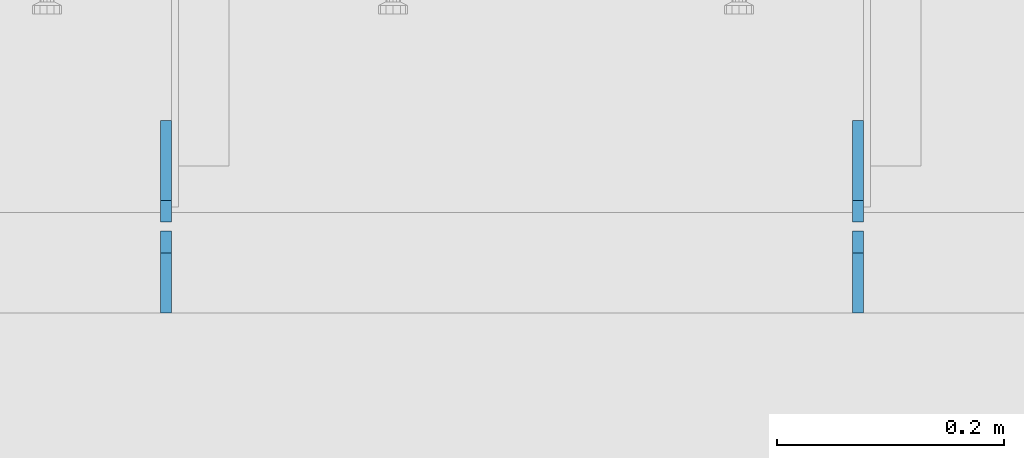
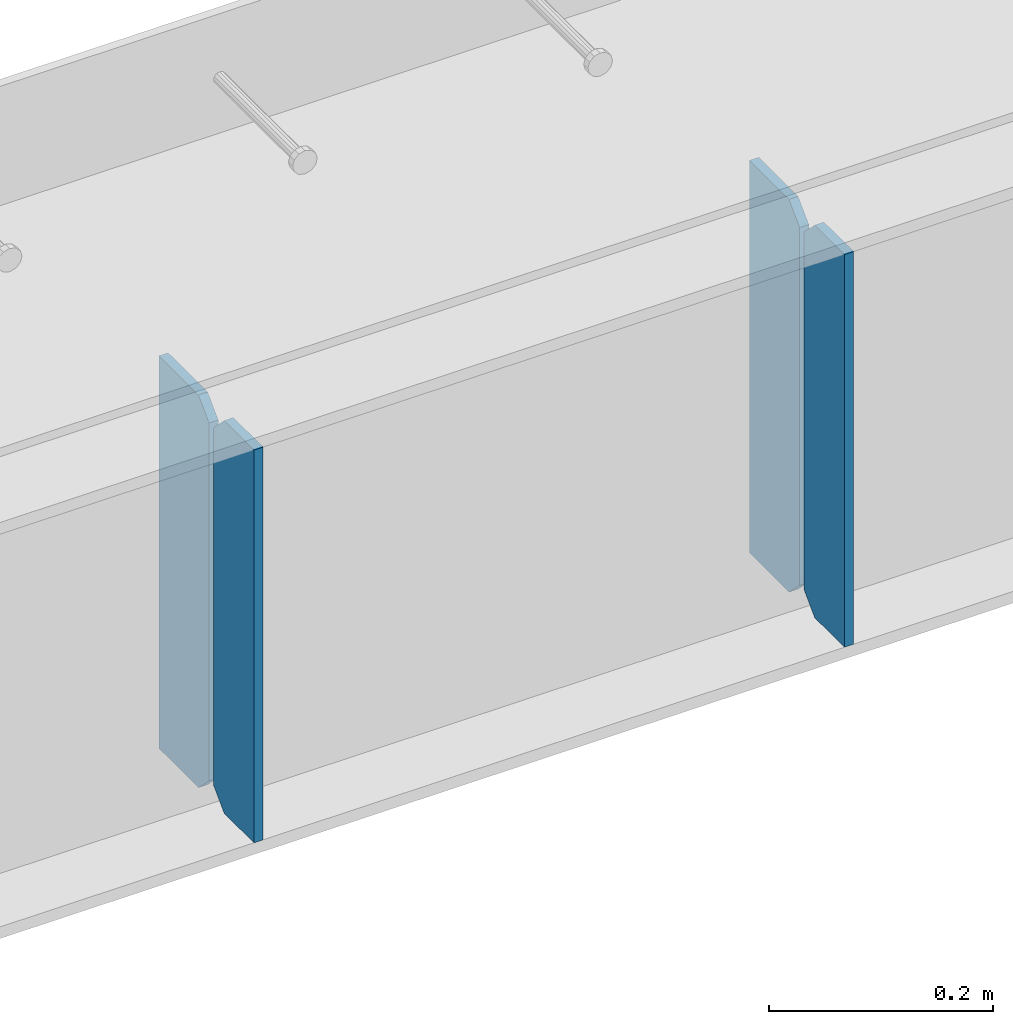
# One storey, part 1613 of 1763: 4 plates, 1 element without a shape of its own.
"""IFC2X3 building model written with IfcOpenShell, lengths in millimetres."""

import ifcopenshell
import ifcopenshell.guid

model = None  # the IFC model being written
_history = None  # IfcOwnerHistory: only IFC2X3 demands one
_inside = {}  # id of a spatial element -> (the spatial element, [elements in it])
_under = {}  # id of a project, library or spatial element -> (it, [spatial elements below it])
_declared = {}  # id of a project -> (the project, [libraries it declares])
_typed = {}  # id of a type object -> (the type object, [elements of that type])
_made_of = {}  # id of a material, layer set ... -> (it, [elements and type objects made of it])


def new_model(schema):
    """Start an empty IFC model of exactly this schema.

    Asked for "IFC4X3", IfcOpenShell would pick the latest addendum, in which some entities
    have other attributes; the version numbers below select the first issue.
    IFC2X3 requires an IfcOwnerHistory on every rooted entity: one is made here for all.
    """
    global model, _history
    if schema == "IFC4X3":
        model = ifcopenshell.file(schema_version=(4, 3, 0, 0))
    else:
        model = ifcopenshell.file(schema=schema)
    _inside.clear()
    _under.clear()
    _declared.clear()
    _typed.clear()
    _made_of.clear()
    _history = None
    if model.schema == "IFC2X3":
        org = make("IfcOrganization", Name="unknown")
        user = make(
            "IfcPersonAndOrganization",
            ThePerson=make("IfcPerson", FamilyName="unknown"),
            TheOrganization=org,
        )
        app = make(
            "IfcApplication",
            ApplicationDeveloper=org,
            Version="unknown",
            ApplicationFullName="unknown",
            ApplicationIdentifier="unknown",
        )
        _history = make(
            "IfcOwnerHistory",
            OwningUser=user,
            OwningApplication=app,
            ChangeAction="ADDED",
            CreationDate=0,
        )
    return model


def make(cls, **values):
    """One entity of the class cls with the attributes given. An attribute that is None is left unset."""
    return model.create_entity(
        cls, **{name: value for name, value in values.items() if value is not None}
    )


def rooted(cls, **values):
    """An entity with a GlobalId (a new one), such as an element, a storey or a relation."""
    return make(cls, GlobalId=ifcopenshell.guid.new(), OwnerHistory=_history, **values)


def si_unit(unit_type, name, prefix=None):
    """IfcSIUnit, for example si_unit("LENGTHUNIT", "METRE", prefix="MILLI")."""
    return make("IfcSIUnit", UnitType=unit_type, Prefix=prefix, Name=name)


def assignment(units):
    """IfcUnitAssignment: the units of a project."""
    return None if units is None else make("IfcUnitAssignment", Units=units)


def point(xyz):
    """IfcCartesianPoint."""
    return None if xyz is None else make("IfcCartesianPoint", Coordinates=xyz)


def direction(xyz):
    """IfcDirection."""
    return None if xyz is None else make("IfcDirection", DirectionRatios=xyz)


def frame(location, z_axis=None, x_axis=None):
    """IfcAxis2Placement3D, a coordinate frame: its origin and axes. An axis left out is left unset."""
    return make(
        "IfcAxis2Placement3D",
        Location=point(location),
        Axis=direction(z_axis),
        RefDirection=direction(x_axis),
    )


def origin_with_axes():
    """The frame at (0, 0, 0) with the z axis (0, 0, 1) and the x axis (1, 0, 0) written out."""
    return frame((0.0, 0.0, 0.0), z_axis=(0.0, 0.0, 1.0), x_axis=(1.0, 0.0, 0.0))


def place(relative_to, where):
    """IfcLocalPlacement: puts the frame where relative to a parent placement (None: the world)."""
    return make(
        "IfcLocalPlacement", PlacementRelTo=relative_to, RelativePlacement=where
    )


def context(
    kind, dimensions, precision=None, world=None, true_north=None, identifier=None
):
    """IfcGeometricRepresentationContext, for example the 3D "Model" context."""
    return make(
        "IfcGeometricRepresentationContext",
        ContextIdentifier=identifier,
        ContextType=kind,
        CoordinateSpaceDimension=dimensions,
        Precision=precision,
        WorldCoordinateSystem=world,
        TrueNorth=true_north,
    )


def subcontext(parent, identifier, kind, view, scale=None):
    """IfcGeometricRepresentationSubContext, for example "Body" below "Model"."""
    return make(
        "IfcGeometricRepresentationSubContext",
        ContextIdentifier=identifier,
        ContextType=kind,
        ParentContext=parent,
        TargetScale=scale,
        TargetView=view,
    )


def project(units=None, contexts=None):
    """IfcProject with its units and contexts."""
    return rooted(
        "IfcProject",
        Name="project",
        RepresentationContexts=contexts,
        UnitsInContext=assignment(units),
    )


def spatial(cls, under=None, at=None, **own):
    """A site, building, storey or space (cls), placed at a placement, below another one or the project."""
    s = rooted(cls, ObjectPlacement=at, **own)
    if under is not None:
        _under.setdefault(under.id(), (under, []))[1].append(s)
    return s


def faces_of(points, faces, orient=None, outer=None):
    """IfcFace entities. A face is a list of loops; a loop is a list of indices into points, from 0.

    orient and outer hold one flag for each loop. By default every Orientation is true, the
    first loop of a face is its IfcFaceOuterBound and the others are IfcFaceBound.
    """
    made = []
    for i, loops in enumerate(faces):
        bounds = []
        for j, loop in enumerate(loops):
            is_outer = j == 0 if outer is None else outer[i][j]
            bounds.append(
                make(
                    "IfcFaceOuterBound" if is_outer else "IfcFaceBound",
                    Bound=make("IfcPolyLoop", Polygon=[points[k] for k in loop]),
                    Orientation=True if orient is None else orient[i][j],
                )
            )
        made.append(make("IfcFace", Bounds=bounds))
    return made


def faceted_brep(points, faces, orient=None, outer=None, voids=None):
    """IfcFacetedBrep: a solid bounded by flat faces; with voids (closed shells), ...WithVoids."""
    shared = [point(p) for p in points]
    hull = make("IfcClosedShell", CfsFaces=faces_of(shared, faces, orient, outer))
    if voids is None:
        return make("IfcFacetedBrep", Outer=hull)
    return make(
        "IfcFacetedBrepWithVoids",
        Outer=hull,
        Voids=[
            make(cls, CfsFaces=faces_of(shared, fs, o, b)) for cls, fs, o, b in voids
        ],
    )


def shape(context_of_items, identifier, shape_type, items):
    """IfcShapeRepresentation: the items that make up one representation, for example the "Body"."""
    return make(
        "IfcShapeRepresentation",
        ContextOfItems=context_of_items,
        RepresentationIdentifier=identifier,
        RepresentationType=shape_type,
        Items=items,
    )


def material(Name=None, Category=None):
    """IfcMaterial."""
    return make("IfcMaterial", Name=Name, Category=Category)


def made_of(thing, what):
    """Note that an element or type object is made of a material, layer set ...; save() writes the relation."""
    if what is not None:
        _made_of.setdefault(what.id(), (what, []))[1].append(thing)
    return thing


def type_object(cls, material=None, **own):
    """A type object (cls), such as IfcWallType, which elements share."""
    return made_of(rooted(cls, **own), material)


def element(
    cls,
    number,
    at=None,
    inside=None,
    cuts=None,
    type_object=None,
    material=None,
    context=None,
    identifier="Body",
    shape_type=None,
    held_by="IfcProductDefinitionShape",
    body=None,
    shapes=None,
    **own,
):
    """One element of the class cls, such as IfcWall. Its Tag is "e" and its number.

    at: its placement. inside: the storey or other place that contains it. cuts: it is an
    opening in that element (IfcRelVoidsElement). A single representation is given by context,
    identifier, shape_type and body (its items); several are given by shapes. held_by: the class
    of the entity that holds the representations. save() writes the other relations.
    """
    e = rooted(cls, Tag="e%d" % number, ObjectPlacement=at, **own)
    if body is not None:
        shapes = [shape(context, identifier, shape_type, body)]
    if shapes is not None:
        e.Representation = make(held_by, Representations=shapes)
    if inside is not None:
        _inside.setdefault(inside.id(), (inside, []))[1].append(e)
    if cuts is not None:
        rooted(
            "IfcRelVoidsElement", RelatingBuildingElement=cuts, RelatedOpeningElement=e
        )
    if type_object is not None:
        _typed.setdefault(type_object.id(), (type_object, []))[1].append(e)
    return made_of(e, material)


def aggregate(whole, parts):
    """IfcRelAggregates: a whole, such as a stair, and the parts it consists of."""
    return rooted("IfcRelAggregates", RelatingObject=whole, RelatedObjects=parts)


def save(model, path):
    """Write the relations noted so far, then the file.

    IfcRelAggregates (storeys below a building ...), IfcRelContainedInSpatialStructure (elements
    in a storey), IfcRelDefinesByType, IfcRelAssociatesMaterial and IfcRelDeclares: one each for
    every whole, place, type object, material and project.
    """
    for whole, parts in _under.values():
        aggregate(whole, parts)
    for where, things in _inside.values():
        rooted(
            "IfcRelContainedInSpatialStructure",
            RelatedElements=things,
            RelatingStructure=where,
        )
    for kind, things in _typed.values():
        rooted("IfcRelDefinesByType", RelatedObjects=things, RelatingType=kind)
    for what, things in _made_of.values():
        rooted("IfcRelAssociatesMaterial", RelatedObjects=things, RelatingMaterial=what)
    for by, libraries in _declared.values():
        rooted("IfcRelDeclares", RelatingContext=by, RelatedDefinitions=libraries)
    model.write(path)


model = new_model("IFC2X3")

# Units and contexts
model_context = context("Model", 3, precision=1e-05, world=origin_with_axes())
body_context = subcontext(model_context, "Body", "Model", "MODEL_VIEW")
ifc_project = project(units=[si_unit("LENGTHUNIT", "METRE", prefix="MILLI"), si_unit("AREAUNIT", "SQUARE_METRE"), si_unit("VOLUMEUNIT", "CUBIC_METRE"), si_unit("MASSUNIT", "GRAM", prefix="KILO"), si_unit("TIMEUNIT", "SECOND"), si_unit("PLANEANGLEUNIT", "RADIAN"), si_unit("SOLIDANGLEUNIT", "STERADIAN"), si_unit("THERMODYNAMICTEMPERATUREUNIT", "DEGREE_CELSIUS"), si_unit("LUMINOUSINTENSITYUNIT", "LUMEN")], contexts=[model_context])

# Site, building, storey
site_placement = place(None, origin_with_axes())
site = spatial("IfcSite", under=ifc_project, at=site_placement, CompositionType="ELEMENT")
building_placement = place(site_placement, origin_with_axes())
building = spatial("IfcBuilding", under=site, at=building_placement, Name="Undefined", CompositionType="ELEMENT")
storey_placement = place(building_placement, origin_with_axes())
storey = spatial("IfcBuildingStorey", under=building, at=storey_placement, Name="Undefined", CompositionType="ELEMENT", Elevation=0.0)

# Assembly, plates
assembly_placement = place(storey_placement, origin_with_axes())
assembly = element("IfcElementAssembly", 1, at=assembly_placement, inside=storey, Name="BEAM", AssemblyPlace="NOTDEFINED", PredefinedType="RIGID_FRAME")
ifc_material = material(Name="STEEL/A36")
plate_type_1 = type_object("IfcPlateType", PredefinedType="NOTDEFINED")
plate_1_placement = place(assembly_placement, frame((-65218.6997736984, 53568.6, 4752.975), z_axis=(0.0, 0.0, 1.0), x_axis=(0.0, 1.0, 0.0)))
plate_1 = element("IfcPlate", 2, at=plate_1_placement, type_object=plate_type_1, material=ifc_material, Name="PLATE", context=body_context, shape_type="Brep", body=[
    faceted_brep([(0.0, -4.76249999999982, 0.0), (0.0, -4.76249999999709, 428.625), (0.0, 4.76249999999709, 428.625), (0.0, 4.76249999999982, 0.0), (53.1812477111816, -4.76249999999709, 428.625), (53.1812477111816, 4.76249999999709, 428.625), (72.2312469482422, -4.76249999999709, 409.575000762939), (72.2312469482422, 4.76249999999709, 409.575000762939), (72.2312469482422, -4.76249999999709, 19.0499992370605), (72.2312469482422, 4.76249999999709, 19.0499992370605), (53.1812477111816, -4.76249999999709, 0.0), (53.1812477111816, 4.76249999999709, 0.0)], [[[0, 1, 2, 3]], [[1, 4, 5, 2]], [[4, 6, 7, 5]], [[6, 8, 9, 7]], [[8, 10, 11, 9]], [[10, 0, 3, 11]], [[5, 7, 9, 11, 3, 2]], [[10, 8, 6, 4, 1, 0]]]),
])
plate_2_placement = place(assembly_placement, frame((-65828.2997736984, 53568.6, 4752.975), z_axis=(0.0, 0.0, 1.0), x_axis=(0.0, 1.0, 0.0)))
plate_2 = element("IfcPlate", 3, at=plate_2_placement, type_object=plate_type_1, material=ifc_material, Name="PLATE", context=body_context, shape_type="Brep", body=[
    faceted_brep([(0.0, -4.76249999999982, 0.0), (0.0, -4.76249999999709, 428.625), (0.0, 4.76249999999709, 428.625), (0.0, 4.76249999999982, 0.0), (53.1812477111816, -4.76249999999709, 428.625), (53.1812477111816, 4.76249999999709, 428.625), (72.2312469482422, -4.76249999999709, 409.575000762939), (72.2312469482422, 4.76249999999709, 409.575000762939), (72.2312469482422, -4.76249999999709, 19.0499992370605), (72.2312469482422, 4.76249999999709, 19.0499992370605), (53.1812477111816, -4.76249999999709, 0.0), (53.1812477111816, 4.76249999999709, 0.0)], [[[0, 1, 2, 3]], [[1, 4, 5, 2]], [[4, 6, 7, 5]], [[6, 8, 9, 7]], [[8, 10, 11, 9]], [[10, 0, 3, 11]], [[5, 7, 9, 11, 3, 2]], [[10, 8, 6, 4, 1, 0]]]),
])
plate_type_2 = type_object("IfcPlateType", PredefinedType="NOTDEFINED")
plate_3_placement = place(assembly_placement, frame((-65218.6997736984, 53648.76875, 4752.975), z_axis=(0.0, 0.0, 1.0), x_axis=(0.0, 1.0, 0.0)))
plate_3 = element("IfcPlate", 4, at=plate_3_placement, type_object=plate_type_2, material=ifc_material, Name="PLATE", context=body_context, shape_type="Brep", body=[
    faceted_brep([(6.96272763889283e-08, -4.76249999999709, 19.0499992370605), (0.0, -4.76249999999709, 409.575000762939), (0.0, 4.76249999999709, 409.575000762939), (6.96454662829638e-08, 4.76249999999709, 19.0499992370605), (19.0499992370605, -4.76249999999709, 428.625), (19.0499992370605, 4.76249999999709, 428.625), (89.6937484741211, -4.76249999999709, 428.625), (89.6937484741211, 4.76249999999709, 428.625), (89.6937484741211, -4.76249999999709, 0.0), (89.6937484741211, 4.76249999999709, 0.0), (19.0499992370533, -4.76249999996799, -2.09183781407773e-11), (19.0499992370678, 4.76250000003347, -2.09183781407773e-11)], [[[0, 1, 2, 3]], [[1, 4, 5, 2]], [[4, 6, 7, 5]], [[6, 8, 9, 7]], [[8, 10, 11, 9]], [[10, 0, 3, 11]], [[5, 7, 9, 11, 3, 2]], [[10, 8, 6, 4, 1, 0]]]),
])
plate_4_placement = place(assembly_placement, frame((-65828.2997736984, 53648.76875, 4752.975), z_axis=(0.0, 0.0, 1.0), x_axis=(0.0, 1.0, 0.0)))
plate_4 = element("IfcPlate", 5, at=plate_4_placement, type_object=plate_type_2, material=ifc_material, Name="PLATE", context=body_context, shape_type="Brep", body=[
    faceted_brep([(6.96272763889283e-08, -4.76249999999709, 19.0499992370605), (0.0, -4.76249999999709, 409.575000762939), (0.0, 4.76249999999709, 409.575000762939), (6.96454662829638e-08, 4.76249999999709, 19.0499992370605), (19.0499992370605, -4.76249999999709, 428.625), (19.0499992370605, 4.76249999999709, 428.625), (89.6937484741211, -4.76249999999709, 428.625), (89.6937484741211, 4.76249999999709, 428.625), (89.6937484741211, -4.76249999999709, 0.0), (89.6937484741211, 4.76249999999709, 0.0), (19.0499992370533, -4.76249999996799, -2.09183781407773e-11), (19.0499992370678, 4.76250000003347, -2.09183781407773e-11)], [[[0, 1, 2, 3]], [[1, 4, 5, 2]], [[4, 6, 7, 5]], [[6, 8, 9, 7]], [[8, 10, 11, 9]], [[10, 0, 3, 11]], [[5, 7, 9, 11, 3, 2]], [[10, 8, 6, 4, 1, 0]]]),
])
aggregate(assembly, [plate_1, plate_3, plate_2, plate_4])

save(model, "model.ifc")
